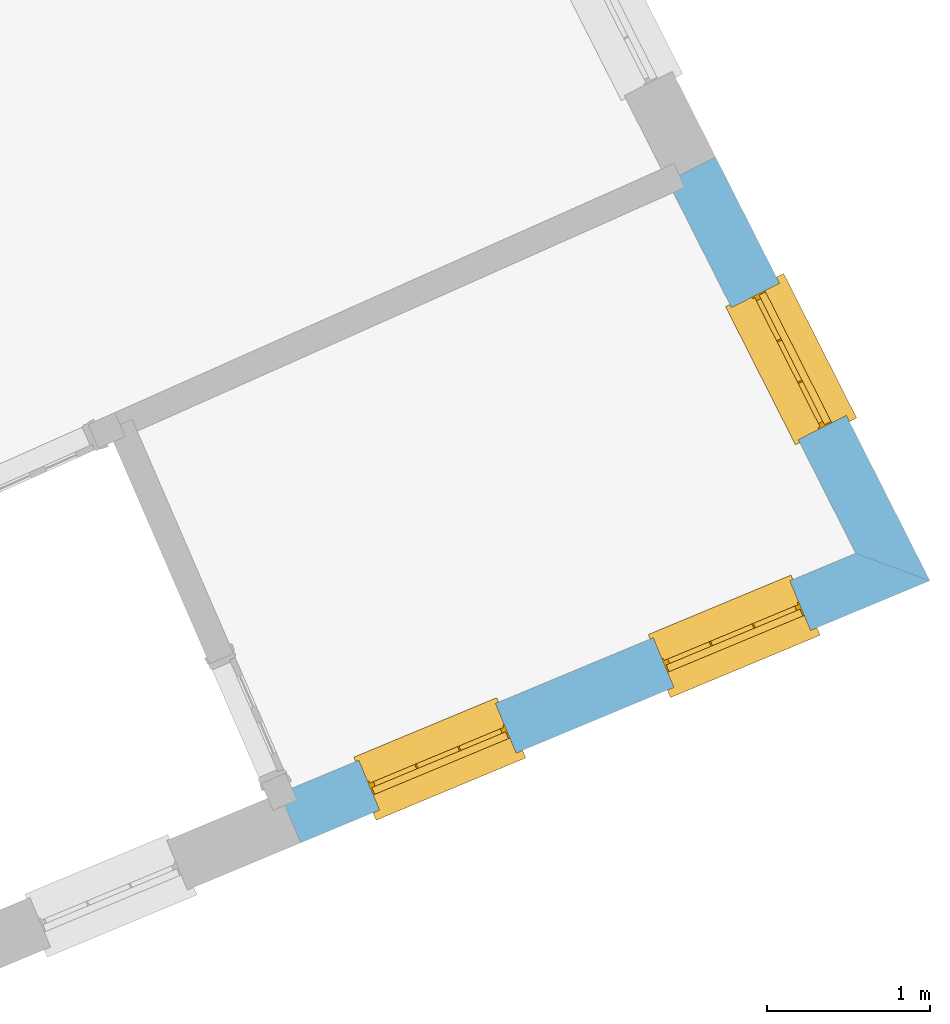
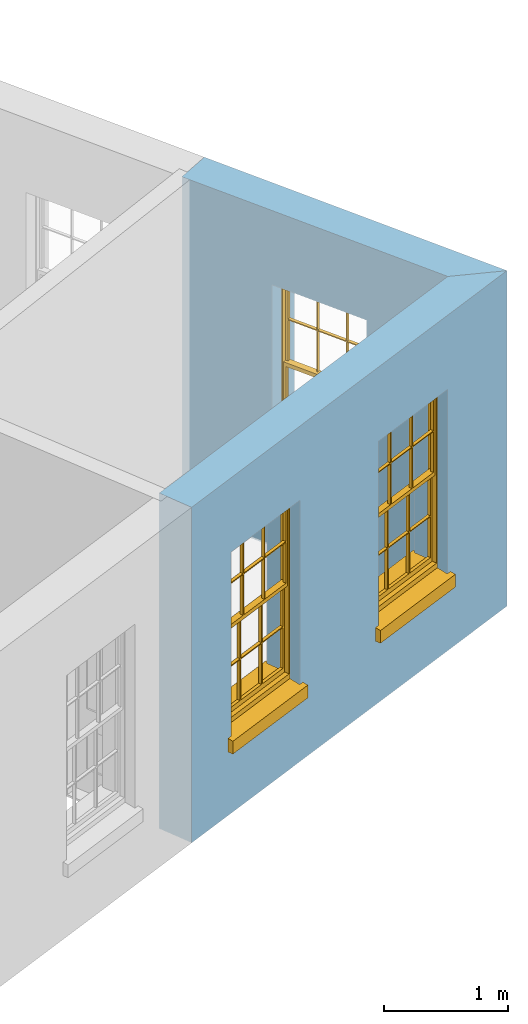
# One storey, part 6 of 8: 3 windows, 3 openings, plus 2 elements that do not belong to this part.
"""IFC2X3 building model written with IfcOpenShell, lengths in metres."""

from ifc_helpers import new_model, si_unit, frame, origin, place, context, subcontext, project, spatial, polyline, outline, extrude, faceted_brep, material, layer, layer_set, layer_usage, element, fill, save


model = new_model("IFC2X3")

# Units and contexts
model_context = context("Model", 3, world=origin())
body_context = subcontext(model_context, "Body", "Model", "MODEL_VIEW")
ifc_project = project(units=[si_unit("PLANEANGLEUNIT", "RADIAN"), si_unit("MASSUNIT", "GRAM", prefix="KILO"), si_unit("FORCEUNIT", "NEWTON", prefix="KILO"), si_unit("LENGTHUNIT", "METRE")], contexts=[model_context])

# Site, building, storey
site_placement = place(None, origin())
site = spatial("IfcSite", under=ifc_project, at=site_placement, CompositionType="ELEMENT")
building_placement = place(None, origin())
building = spatial("IfcBuilding", under=site, at=building_placement, Name="Building plot-1", CompositionType="ELEMENT")
storey_placement = place(None, frame((0.0, 0.0, 5.15)))
storey = spatial("IfcBuildingStorey", under=building, at=storey_placement, Name="Floor 1", CompositionType="ELEMENT", Elevation=5.15)

# Wall, openings, windows
ifc_material = material(Name="Masonry")
ifc_layer = layer(ifc_material, 0.33, ventilated=False)
ifc_layer_set = layer_set([ifc_layer], Name="My Wall")
ifc_layer_usage = layer_usage(ifc_layer_set, "AXIS2", "NEGATIVE", 0.08)
wall_1_placement = place(storey_placement, origin())
wall_1 = element("IfcWallStandardCase", 1, at=wall_1_placement, inside=storey, material=ifc_layer_usage, Name="exterior", context=body_context, shape_type="SweptSolid", body=[
    extrude(outline(polyline([(28.7035398456304, 43.2516426971912), (28.8304515653399, 42.947022580652), (32.693625357205, 44.5565092916169), (32.2388263663203, 44.7245240587508), (28.7035398456304, 43.2516426971912)])), origin(), (0.0, 0.0, 1.0), 3.3),
])
opening_1_placement = place(storey_placement, frame((0.0, 0.0, 0.75)))
opening_1 = element("IfcOpeningElement", 2, at=opening_1_placement, cuts=wall_1, Name="Opening", ObjectType="Opening", context=body_context, shape_type="SweptSolid", body=[
    extrude(outline(polyline([(29.314138627022, 43.1485376923154), (30.1541516756604, 43.4985063739387), (30.0272399559509, 43.8031264904779), (29.1872269073124, 43.4531578088546), (29.314138627022, 43.1485376923154)])), origin(), (0.0, 0.0, 1.0), 1.82),
])
opening_2_placement = place(storey_placement, frame((0.0, 0.0, 0.75)))
opening_2 = element("IfcOpeningElement", 3, at=opening_2_placement, cuts=wall_1, Name="Opening", ObjectType="Opening", context=body_context, shape_type="SweptSolid", body=[
    extrude(outline(polyline([(31.1215257990245, 43.9015365972656), (31.9615388476629, 44.2515052788889), (31.8346271279534, 44.5561253954281), (30.994614079315, 44.2061567138048), (31.1215257990245, 43.9015365972656)])), origin(), (0.0, 0.0, 1.0), 1.82),
])
window_1_placement = place(storey_placement, frame((29.2179933848178, 43.3793105078754, 0.75), z_axis=(0.0, 0.0, 1.0), x_axis=(0.840013048638443, 0.349968681623295, 0.0)))
window_1 = element("IfcWindow", 4, at=window_1_placement, inside=storey, Name="toilet outside window", OverallHeight=1.82, OverallWidth=0.91, context=body_context, shape_type="Brep", held_by="IfcProductRepresentation", body=[
    faceted_brep([(0.033125, -0.105, 0.975209), (0.01, -0.105, 0.975209), (0.033125, -0.105, 1.376042), (0.876875, -0.105, 0.975209), (0.876875, -0.105, 1.376042), (0.9, -0.105, 0.975209), (0.876875, -0.105, 1.386042), (0.876875, -0.105, 1.786875), (0.9, -0.105, 1.81), (0.033125, -0.105, 1.786875), (0.033125, -0.105, 1.386042), (0.01, -0.105, 1.81), (0.876875, -0.135, 1.376042), (0.876875, -0.135, 0.975209), (0.9, -0.135, 0.937083), (0.033125, -0.135, 1.786875), (0.01, -0.135, 1.81), (0.033125, -0.135, 1.386042), (0.01, -0.135, 0.937083), (0.033125, -0.135, 0.975209), (0.033125, -0.135, 1.376042), (0.876875, -0.135, 1.786875), (0.876875, -0.135, 1.386042), (0.9, -0.135, 1.81), (0.033125, -0.105, 0.937083), (0.01, -0.105, 0.937083), (0.033125, -0.105, 0.53625), (0.876875, -0.105, 0.937083), (0.876875, -0.105, 0.53625), (0.9, -0.105, 0.937083), (0.876875, -0.105, 0.52625), (0.876875, -0.105, 0.125417), (0.9, -0.105, 0.077167), (0.033125, -0.105, 0.125417), (0.033125, -0.105, 0.52625), (0.01, -0.105, 0.077167), (-0.0425, -0.25, 0.01), (-0.0425, -0.3, 0.001667), (0.0, -0.25, 0.01), (0.9525, -0.25, 0.01), (0.91, -0.25, 0.01), (0.9525, -0.3, 0.001667), (-0.02, 0.08, 0.077167), (0.0, 0.08, 0.077167), (-0.02, 0.11, 0.077167), (0.0, -0.06, 0.077167), (0.01, -0.06, 0.077167), (0.91, -0.06, 0.077167), (0.91, 0.08, 0.077167), (0.9, -0.06, 0.077167), (0.93, 0.08, 0.077167), (0.93, 0.11, 0.077167), (0.01, -0.075, 0.975209), (0.9, -0.075, 0.975209), (0.876875, -0.075, 0.125417), (0.876875, -0.075, 0.52625), (0.9, -0.075, 0.077167), (0.876875, -0.075, 0.53625), (0.876875, -0.075, 0.937083), (0.033125, -0.075, 0.125417), (0.01, -0.075, 0.077167), (0.033125, -0.075, 0.52625), (0.033125, -0.075, 0.937083), (0.033125, -0.075, 0.53625), (-0.02, 0.08, 0.052167), (-0.02, 0.11, 0.052167), (0.93, 0.11, 0.052167), (0.93, 0.08, 0.052167), (0.91, 0.08, 0.052167), (0.0, 0.08, 0.052167), (0.91, -0.15, 0.026667), (0.0, -0.15, 0.026667), (-0.0425, -0.3, -0.123333), (0.9525, -0.3, -0.123333), (-0.0425, -0.25, -0.123333), (0.9525, -0.25, -0.123333), (0.01, -0.06, 1.81), (0.9, -0.06, 1.81), (0.0, -0.06, 1.82), (0.91, -0.06, 1.82), (0.01, -0.15, 0.077167), (0.9, -0.15, 0.077167), (0.592292, -0.105, 0.125417), (0.592292, -0.075, 0.125417), (0.317708, -0.075, 0.125417), (0.317708, -0.105, 0.125417), (0.592292, -0.105, 0.53625), (0.317708, -0.105, 0.53625), (0.317708, -0.105, 0.52625), (0.592292, -0.105, 0.52625), (0.592292, -0.075, 0.53625), (0.317708, -0.075, 0.53625), (0.592292, -0.135, 1.386042), (0.592292, -0.105, 1.386042), (0.317708, -0.105, 1.386042), (0.317708, -0.135, 1.386042), (0.317708, -0.135, 1.376042), (0.592292, -0.135, 1.376042), (0.317708, -0.105, 1.376042), (0.592292, -0.105, 1.376042), (0.602292, -0.135, 1.376042), (0.592292, -0.135, 0.975209), (0.602292, -0.135, 0.975209), (0.602292, -0.105, 0.975209), (0.592292, -0.105, 0.975209), (0.602292, -0.105, 1.376042), (0.602292, -0.075, 0.53625), (0.602292, -0.105, 0.53625), (0.317708, -0.075, 0.52625), (0.307708, -0.075, 0.125417), (0.307708, -0.075, 0.52625), (0.602292, -0.075, 0.52625), (0.602292, -0.075, 0.125417), (0.592292, -0.075, 0.52625), (0.307708, -0.075, 0.53625), (0.317708, -0.075, 0.937083), (0.307708, -0.075, 0.937083), (0.602292, -0.075, 0.937083), (0.592292, -0.075, 0.937083), (0.307708, -0.105, 0.52625), (0.307708, -0.105, 0.125417), (0.307708, -0.105, 0.53625), (0.307708, -0.105, 0.937083), (0.592292, -0.105, 0.937083), (0.317708, -0.105, 0.937083), (0.602292, -0.105, 0.937083), (0.602292, -0.105, 0.52625), (0.602292, -0.105, 0.125417), (0.307708, -0.135, 1.386042), (0.307708, -0.135, 1.376042), (0.307708, -0.135, 0.975209), (0.317708, -0.135, 0.975209), (0.317708, -0.135, 1.786875), (0.307708, -0.135, 1.786875), (0.602292, -0.135, 1.786875), (0.592292, -0.135, 1.786875), (0.602292, -0.135, 1.386042), (0.602292, -0.105, 1.386042), (0.307708, -0.105, 1.386042), (0.307708, -0.105, 1.786875), (0.317708, -0.105, 1.786875), (0.592292, -0.105, 1.786875), (0.602292, -0.105, 1.786875), (0.307708, -0.105, 1.376042), (0.317708, -0.105, 0.975209), (0.307708, -0.105, 0.975209), (0.91, -0.15, 1.82), (0.9, -0.15, 1.81), (0.01, -0.15, 1.81), (0.0, -0.15, 1.82), (0.91, -0.25, 0.0), (0.0, -0.25, 0.0), (0.91, 0.08, 0.0), (0.0, 0.08, 0.0)], [[[0, 1, 2]], [[3, 4, 5]], [[6, 7, 8]], [[9, 10, 11]], [[12, 13, 14]], [[15, 16, 17]], [[18, 19, 20]], [[21, 22, 23]], [[24, 25, 26]], [[27, 28, 29]], [[30, 31, 32]], [[33, 34, 35]], [[14, 27, 29]], [[25, 24, 18]], [[36, 37, 38]], [[39, 40, 41]], [[42, 43, 44]], [[45, 46, 43]], [[47, 48, 49]], [[50, 51, 48]], [[1, 0, 52]], [[5, 53, 3]], [[54, 55, 56]], [[57, 58, 53]], [[59, 60, 61]], [[62, 63, 52]], [[48, 43, 46, 49]], [[51, 44, 43, 48]], [[64, 42, 44, 65]], [[65, 44, 51, 66]], [[66, 51, 50, 67]], [[65, 66, 68, 69]], [[60, 56, 49, 46]], [[70, 71, 38, 40]], [[37, 41, 40, 38]], [[37, 72, 73, 41]], [[74, 75, 73, 72]], [[8, 11, 76, 77]], [[76, 78, 79, 77]], [[32, 35, 80, 81]], [[81, 80, 71, 70]], [[82, 83, 84, 85]], [[86, 87, 88, 89]], [[86, 90, 91, 87]], [[92, 93, 94, 95]], [[92, 95, 96, 97]], [[96, 98, 99, 97]], [[100, 97, 101, 102]], [[103, 104, 99, 105]], [[97, 99, 104, 101]], [[102, 103, 105, 100]], [[28, 57, 106, 107]], [[108, 84, 109, 110]], [[111, 112, 83, 113]], [[114, 110, 61, 63]], [[90, 113, 108, 91]], [[115, 91, 114, 116]], [[117, 106, 90, 118]], [[111, 106, 57, 55]], [[119, 110, 109, 120]], [[34, 61, 110, 119]], [[89, 113, 83, 82]], [[88, 108, 113, 89]], [[85, 84, 108, 88]], [[121, 114, 63, 26]], [[122, 116, 114, 121]], [[123, 118, 90, 86]], [[87, 91, 115, 124]], [[107, 106, 117, 125]], [[126, 111, 55, 30]], [[127, 112, 111, 126]], [[126, 30, 28, 107]], [[88, 119, 120, 85]], [[126, 89, 82, 127]], [[125, 123, 86, 107]], [[121, 26, 34, 119]], [[124, 122, 121, 87]], [[128, 17, 20, 129]], [[96, 129, 130, 131]], [[132, 133, 128, 95]], [[134, 135, 92, 136]], [[100, 12, 22, 136]], [[137, 6, 4, 105]], [[94, 138, 139, 140]], [[137, 93, 141, 142]], [[99, 98, 94, 93]], [[143, 2, 10, 138]], [[144, 145, 143, 98]], [[129, 143, 145, 130]], [[20, 2, 143, 129]], [[131, 144, 98, 96]], [[128, 138, 10, 17]], [[133, 139, 138, 128]], [[135, 141, 93, 92]], [[95, 94, 140, 132]], [[22, 6, 137, 136]], [[136, 137, 142, 134]], [[100, 105, 4, 12]], [[107, 86, 89, 126]], [[106, 111, 113, 90]], [[91, 108, 110, 114]], [[87, 121, 119, 88]], [[97, 100, 136, 92]], [[129, 96, 95, 128]], [[98, 143, 138, 94]], [[105, 99, 93, 137]], [[131, 101, 104, 144]], [[124, 115, 118, 123]], [[132, 140, 141, 135]], [[120, 109, 59, 33]], [[15, 9, 139, 133]], [[134, 142, 7, 21]], [[31, 54, 112, 127]], [[36, 74, 72, 37]], [[39, 41, 73, 75]], [[18, 14, 101, 131]], [[23, 16, 132, 135]], [[83, 56, 60, 84]], [[52, 53, 118, 115]], [[53, 52, 144, 104]], [[11, 8, 141, 140]], [[14, 18, 124, 123]], [[2, 1, 11, 10]], [[8, 5, 4, 6]], [[57, 53, 56, 55]], [[60, 52, 63, 61]], [[26, 25, 35, 34]], [[32, 29, 28, 30]], [[14, 23, 22, 12]], [[18, 20, 17, 16]], [[19, 0, 2, 20]], [[17, 10, 9, 15]], [[12, 4, 3, 13]], [[21, 7, 6, 22]], [[27, 58, 57, 28]], [[30, 55, 54, 31]], [[33, 59, 61, 34]], [[26, 63, 62, 24]], [[5, 8, 77, 53]], [[76, 11, 1, 52]], [[46, 45, 78, 76]], [[49, 77, 79, 47]], [[70, 146, 147, 81]], [[71, 80, 148, 149]], [[19, 130, 145, 0]], [[102, 13, 3, 103]], [[116, 122, 24, 62]], [[29, 32, 81, 14]], [[80, 35, 25, 18]], [[60, 46, 76, 52]], [[77, 49, 56, 53]], [[23, 14, 81, 147]], [[16, 148, 80, 18]], [[35, 85, 120]], [[120, 33, 35]], [[127, 82, 32]], [[32, 31, 127]], [[32, 82, 85, 35]], [[102, 101, 14]], [[14, 13, 102]], [[18, 131, 130]], [[130, 19, 18]], [[134, 21, 23]], [[23, 135, 134]], [[16, 15, 133]], [[133, 132, 16]], [[11, 140, 139]], [[139, 9, 11]], [[142, 141, 8]], [[8, 7, 142]], [[23, 147, 148, 16]], [[146, 149, 148, 147]], [[52, 115, 116]], [[116, 62, 52]], [[118, 53, 117]], [[58, 117, 53]], [[27, 125, 117, 58]], [[56, 83, 112]], [[112, 54, 56]], [[109, 84, 60]], [[60, 59, 109]], [[125, 27, 14]], [[14, 123, 125]], [[122, 124, 18]], [[18, 24, 122]], [[145, 144, 52]], [[52, 0, 145]], [[103, 3, 53]], [[53, 104, 103]], [[79, 78, 149, 146]], [[78, 45, 71, 149]], [[146, 70, 47, 79]], [[150, 75, 74, 151]], [[68, 66, 67]], [[48, 68, 67, 50]], [[69, 64, 65]], [[42, 64, 69, 43]], [[69, 68, 152, 153]], [[70, 68, 48, 47]], [[150, 152, 68, 70]], [[43, 69, 71, 45]], [[69, 153, 151, 71]], [[152, 150, 151, 153]], [[38, 151, 74, 36]], [[71, 151, 38]], [[39, 75, 150, 40]], [[40, 150, 70]]]),
])
fill(opening_1, window_1)
window_2_placement = place(storey_placement, frame((31.0253805568203, 44.1323094128256, 0.75), z_axis=(0.0, 0.0, 1.0), x_axis=(0.840013048638443, 0.349968681623295, 0.0)))
window_2 = element("IfcWindow", 5, at=window_2_placement, inside=storey, Name="toilet outside window", OverallHeight=1.82, OverallWidth=0.91, context=body_context, shape_type="Brep", held_by="IfcProductRepresentation", body=[
    faceted_brep([(0.033125, -0.105, 0.975209), (0.01, -0.105, 0.975209), (0.033125, -0.105, 1.376042), (0.876875, -0.105, 0.975209), (0.876875, -0.105, 1.376042), (0.9, -0.105, 0.975209), (0.876875, -0.105, 1.386042), (0.876875, -0.105, 1.786875), (0.9, -0.105, 1.81), (0.033125, -0.105, 1.786875), (0.033125, -0.105, 1.386042), (0.01, -0.105, 1.81), (0.876875, -0.135, 1.376042), (0.876875, -0.135, 0.975209), (0.9, -0.135, 0.937083), (0.033125, -0.135, 1.786875), (0.01, -0.135, 1.81), (0.033125, -0.135, 1.386042), (0.01, -0.135, 0.937083), (0.033125, -0.135, 0.975209), (0.033125, -0.135, 1.376042), (0.876875, -0.135, 1.786875), (0.876875, -0.135, 1.386042), (0.9, -0.135, 1.81), (0.033125, -0.105, 0.937083), (0.01, -0.105, 0.937083), (0.033125, -0.105, 0.53625), (0.876875, -0.105, 0.937083), (0.876875, -0.105, 0.53625), (0.9, -0.105, 0.937083), (0.876875, -0.105, 0.52625), (0.876875, -0.105, 0.125417), (0.9, -0.105, 0.077167), (0.033125, -0.105, 0.125417), (0.033125, -0.105, 0.52625), (0.01, -0.105, 0.077167), (-0.0425, -0.25, 0.01), (-0.0425, -0.3, 0.001667), (0.0, -0.25, 0.01), (0.9525, -0.25, 0.01), (0.91, -0.25, 0.01), (0.9525, -0.3, 0.001667), (-0.02, 0.08, 0.077167), (0.0, 0.08, 0.077167), (-0.02, 0.11, 0.077167), (0.0, -0.06, 0.077167), (0.01, -0.06, 0.077167), (0.91, -0.06, 0.077167), (0.91, 0.08, 0.077167), (0.9, -0.06, 0.077167), (0.93, 0.08, 0.077167), (0.93, 0.11, 0.077167), (0.01, -0.075, 0.975209), (0.9, -0.075, 0.975209), (0.876875, -0.075, 0.125417), (0.876875, -0.075, 0.52625), (0.9, -0.075, 0.077167), (0.876875, -0.075, 0.53625), (0.876875, -0.075, 0.937083), (0.033125, -0.075, 0.125417), (0.01, -0.075, 0.077167), (0.033125, -0.075, 0.52625), (0.033125, -0.075, 0.937083), (0.033125, -0.075, 0.53625), (-0.02, 0.08, 0.052167), (-0.02, 0.11, 0.052167), (0.93, 0.11, 0.052167), (0.93, 0.08, 0.052167), (0.91, 0.08, 0.052167), (0.0, 0.08, 0.052167), (0.91, -0.15, 0.026667), (0.0, -0.15, 0.026667), (-0.0425, -0.3, -0.123333), (0.9525, -0.3, -0.123333), (-0.0425, -0.25, -0.123333), (0.9525, -0.25, -0.123333), (0.01, -0.06, 1.81), (0.9, -0.06, 1.81), (0.0, -0.06, 1.82), (0.91, -0.06, 1.82), (0.01, -0.15, 0.077167), (0.9, -0.15, 0.077167), (0.592292, -0.105, 0.125417), (0.592292, -0.075, 0.125417), (0.317708, -0.075, 0.125417), (0.317708, -0.105, 0.125417), (0.592292, -0.105, 0.53625), (0.317708, -0.105, 0.53625), (0.317708, -0.105, 0.52625), (0.592292, -0.105, 0.52625), (0.592292, -0.075, 0.53625), (0.317708, -0.075, 0.53625), (0.592292, -0.135, 1.386042), (0.592292, -0.105, 1.386042), (0.317708, -0.105, 1.386042), (0.317708, -0.135, 1.386042), (0.317708, -0.135, 1.376042), (0.592292, -0.135, 1.376042), (0.317708, -0.105, 1.376042), (0.592292, -0.105, 1.376042), (0.602292, -0.135, 1.376042), (0.592292, -0.135, 0.975209), (0.602292, -0.135, 0.975209), (0.602292, -0.105, 0.975209), (0.592292, -0.105, 0.975209), (0.602292, -0.105, 1.376042), (0.602292, -0.075, 0.53625), (0.602292, -0.105, 0.53625), (0.317708, -0.075, 0.52625), (0.307708, -0.075, 0.125417), (0.307708, -0.075, 0.52625), (0.602292, -0.075, 0.52625), (0.602292, -0.075, 0.125417), (0.592292, -0.075, 0.52625), (0.307708, -0.075, 0.53625), (0.317708, -0.075, 0.937083), (0.307708, -0.075, 0.937083), (0.602292, -0.075, 0.937083), (0.592292, -0.075, 0.937083), (0.307708, -0.105, 0.52625), (0.307708, -0.105, 0.125417), (0.307708, -0.105, 0.53625), (0.307708, -0.105, 0.937083), (0.592292, -0.105, 0.937083), (0.317708, -0.105, 0.937083), (0.602292, -0.105, 0.937083), (0.602292, -0.105, 0.52625), (0.602292, -0.105, 0.125417), (0.307708, -0.135, 1.386042), (0.307708, -0.135, 1.376042), (0.307708, -0.135, 0.975209), (0.317708, -0.135, 0.975209), (0.317708, -0.135, 1.786875), (0.307708, -0.135, 1.786875), (0.602292, -0.135, 1.786875), (0.592292, -0.135, 1.786875), (0.602292, -0.135, 1.386042), (0.602292, -0.105, 1.386042), (0.307708, -0.105, 1.386042), (0.307708, -0.105, 1.786875), (0.317708, -0.105, 1.786875), (0.592292, -0.105, 1.786875), (0.602292, -0.105, 1.786875), (0.307708, -0.105, 1.376042), (0.317708, -0.105, 0.975209), (0.307708, -0.105, 0.975209), (0.91, -0.15, 1.82), (0.9, -0.15, 1.81), (0.01, -0.15, 1.81), (0.0, -0.15, 1.82), (0.91, -0.25, 0.0), (0.0, -0.25, 0.0), (0.91, 0.08, 0.0), (0.0, 0.08, 0.0)], [[[0, 1, 2]], [[3, 4, 5]], [[6, 7, 8]], [[9, 10, 11]], [[12, 13, 14]], [[15, 16, 17]], [[18, 19, 20]], [[21, 22, 23]], [[24, 25, 26]], [[27, 28, 29]], [[30, 31, 32]], [[33, 34, 35]], [[14, 27, 29]], [[25, 24, 18]], [[36, 37, 38]], [[39, 40, 41]], [[42, 43, 44]], [[45, 46, 43]], [[47, 48, 49]], [[50, 51, 48]], [[1, 0, 52]], [[5, 53, 3]], [[54, 55, 56]], [[57, 58, 53]], [[59, 60, 61]], [[62, 63, 52]], [[48, 43, 46, 49]], [[51, 44, 43, 48]], [[64, 42, 44, 65]], [[65, 44, 51, 66]], [[66, 51, 50, 67]], [[65, 66, 68, 69]], [[60, 56, 49, 46]], [[70, 71, 38, 40]], [[37, 41, 40, 38]], [[37, 72, 73, 41]], [[74, 75, 73, 72]], [[8, 11, 76, 77]], [[76, 78, 79, 77]], [[32, 35, 80, 81]], [[81, 80, 71, 70]], [[82, 83, 84, 85]], [[86, 87, 88, 89]], [[86, 90, 91, 87]], [[92, 93, 94, 95]], [[92, 95, 96, 97]], [[96, 98, 99, 97]], [[100, 97, 101, 102]], [[103, 104, 99, 105]], [[97, 99, 104, 101]], [[102, 103, 105, 100]], [[28, 57, 106, 107]], [[108, 84, 109, 110]], [[111, 112, 83, 113]], [[114, 110, 61, 63]], [[90, 113, 108, 91]], [[115, 91, 114, 116]], [[117, 106, 90, 118]], [[111, 106, 57, 55]], [[119, 110, 109, 120]], [[34, 61, 110, 119]], [[89, 113, 83, 82]], [[88, 108, 113, 89]], [[85, 84, 108, 88]], [[121, 114, 63, 26]], [[122, 116, 114, 121]], [[123, 118, 90, 86]], [[87, 91, 115, 124]], [[107, 106, 117, 125]], [[126, 111, 55, 30]], [[127, 112, 111, 126]], [[126, 30, 28, 107]], [[88, 119, 120, 85]], [[126, 89, 82, 127]], [[125, 123, 86, 107]], [[121, 26, 34, 119]], [[124, 122, 121, 87]], [[128, 17, 20, 129]], [[96, 129, 130, 131]], [[132, 133, 128, 95]], [[134, 135, 92, 136]], [[100, 12, 22, 136]], [[137, 6, 4, 105]], [[94, 138, 139, 140]], [[137, 93, 141, 142]], [[99, 98, 94, 93]], [[143, 2, 10, 138]], [[144, 145, 143, 98]], [[129, 143, 145, 130]], [[20, 2, 143, 129]], [[131, 144, 98, 96]], [[128, 138, 10, 17]], [[133, 139, 138, 128]], [[135, 141, 93, 92]], [[95, 94, 140, 132]], [[22, 6, 137, 136]], [[136, 137, 142, 134]], [[100, 105, 4, 12]], [[107, 86, 89, 126]], [[106, 111, 113, 90]], [[91, 108, 110, 114]], [[87, 121, 119, 88]], [[97, 100, 136, 92]], [[129, 96, 95, 128]], [[98, 143, 138, 94]], [[105, 99, 93, 137]], [[131, 101, 104, 144]], [[124, 115, 118, 123]], [[132, 140, 141, 135]], [[120, 109, 59, 33]], [[15, 9, 139, 133]], [[134, 142, 7, 21]], [[31, 54, 112, 127]], [[36, 74, 72, 37]], [[39, 41, 73, 75]], [[18, 14, 101, 131]], [[23, 16, 132, 135]], [[83, 56, 60, 84]], [[52, 53, 118, 115]], [[53, 52, 144, 104]], [[11, 8, 141, 140]], [[14, 18, 124, 123]], [[2, 1, 11, 10]], [[8, 5, 4, 6]], [[57, 53, 56, 55]], [[60, 52, 63, 61]], [[26, 25, 35, 34]], [[32, 29, 28, 30]], [[14, 23, 22, 12]], [[18, 20, 17, 16]], [[19, 0, 2, 20]], [[17, 10, 9, 15]], [[12, 4, 3, 13]], [[21, 7, 6, 22]], [[27, 58, 57, 28]], [[30, 55, 54, 31]], [[33, 59, 61, 34]], [[26, 63, 62, 24]], [[5, 8, 77, 53]], [[76, 11, 1, 52]], [[46, 45, 78, 76]], [[49, 77, 79, 47]], [[70, 146, 147, 81]], [[71, 80, 148, 149]], [[19, 130, 145, 0]], [[102, 13, 3, 103]], [[116, 122, 24, 62]], [[29, 32, 81, 14]], [[80, 35, 25, 18]], [[60, 46, 76, 52]], [[77, 49, 56, 53]], [[23, 14, 81, 147]], [[16, 148, 80, 18]], [[35, 85, 120]], [[120, 33, 35]], [[127, 82, 32]], [[32, 31, 127]], [[32, 82, 85, 35]], [[102, 101, 14]], [[14, 13, 102]], [[18, 131, 130]], [[130, 19, 18]], [[134, 21, 23]], [[23, 135, 134]], [[16, 15, 133]], [[133, 132, 16]], [[11, 140, 139]], [[139, 9, 11]], [[142, 141, 8]], [[8, 7, 142]], [[23, 147, 148, 16]], [[146, 149, 148, 147]], [[52, 115, 116]], [[116, 62, 52]], [[118, 53, 117]], [[58, 117, 53]], [[27, 125, 117, 58]], [[56, 83, 112]], [[112, 54, 56]], [[109, 84, 60]], [[60, 59, 109]], [[125, 27, 14]], [[14, 123, 125]], [[122, 124, 18]], [[18, 24, 122]], [[145, 144, 52]], [[52, 0, 145]], [[103, 3, 53]], [[53, 104, 103]], [[79, 78, 149, 146]], [[78, 45, 71, 149]], [[146, 70, 47, 79]], [[150, 75, 74, 151]], [[68, 66, 67]], [[48, 68, 67, 50]], [[69, 64, 65]], [[42, 64, 69, 43]], [[69, 68, 152, 153]], [[70, 68, 48, 47]], [[150, 152, 68, 70]], [[43, 69, 71, 45]], [[69, 153, 151, 71]], [[152, 150, 151, 153]], [[38, 151, 74, 36]], [[71, 151, 38]], [[39, 75, 150, 40]], [[40, 150, 70]]]),
])
fill(opening_2, window_2)

# Wall, opening, window
wall_2_placement = place(storey_placement, origin())
wall_2 = element("IfcWallStandardCase", 6, at=wall_2_placement, inside=storey, material=ifc_layer_usage, Name="exterior", context=body_context, shape_type="SweptSolid", body=[
    extrude(outline(polyline([(32.2388263663203, 44.7245240587508), (32.693625357205, 44.5565092916169), (31.3782721430408, 47.1569525196551), (31.083799749939, 47.0080028311663), (32.2388263663203, 44.7245240587508)])), origin(), (0.0, 0.0, 1.0), 3.3),
])
opening_3_placement = place(storey_placement, frame((0.0, 0.0, 0.75)))
opening_3 = element("IfcOpeningElement", 7, at=opening_3_placement, cuts=wall_2, Name="Opening", ObjectType="Opening", context=body_context, shape_type="SweptSolid", body=[
    extrude(outline(polyline([(32.180589003273, 45.5707782331861), (31.7698489531979, 46.3828081656789), (31.4753765600961, 46.2338584771901), (31.8861166101712, 45.4218285446973), (32.180589003273, 45.5707782331861)])), origin(), (0.0, 0.0, 1.0), 1.82),
])
window_3_placement = place(storey_placement, frame((31.9575038569838, 45.4579375600885, 0.75), z_axis=(0.0, 0.0, 1.0), x_axis=(-0.41074005007513, 0.812029932492806, 0.0)))
window_3 = element("IfcWindow", 8, at=window_3_placement, inside=storey, Name="toilet outside window", OverallHeight=1.82, OverallWidth=0.91, context=body_context, shape_type="Brep", held_by="IfcProductRepresentation", body=[
    faceted_brep([(0.033125, -0.105, 0.975209), (0.01, -0.105, 0.975209), (0.033125, -0.105, 1.376042), (0.876875, -0.105, 0.975209), (0.876875, -0.105, 1.376042), (0.9, -0.105, 0.975209), (0.876875, -0.105, 1.386042), (0.876875, -0.105, 1.786875), (0.9, -0.105, 1.81), (0.033125, -0.105, 1.786875), (0.033125, -0.105, 1.386042), (0.01, -0.105, 1.81), (0.876875, -0.135, 1.376042), (0.876875, -0.135, 0.975209), (0.9, -0.135, 0.937083), (0.033125, -0.135, 1.786875), (0.01, -0.135, 1.81), (0.033125, -0.135, 1.386042), (0.01, -0.135, 0.937083), (0.033125, -0.135, 0.975209), (0.033125, -0.135, 1.376042), (0.876875, -0.135, 1.786875), (0.876875, -0.135, 1.386042), (0.9, -0.135, 1.81), (0.033125, -0.105, 0.937083), (0.01, -0.105, 0.937083), (0.033125, -0.105, 0.53625), (0.876875, -0.105, 0.937083), (0.876875, -0.105, 0.53625), (0.9, -0.105, 0.937083), (0.876875, -0.105, 0.52625), (0.876875, -0.105, 0.125417), (0.9, -0.105, 0.077167), (0.033125, -0.105, 0.125417), (0.033125, -0.105, 0.52625), (0.01, -0.105, 0.077167), (-0.0425, -0.25, 0.01), (-0.0425, -0.3, 0.001667), (0.0, -0.25, 0.01), (0.9525, -0.25, 0.01), (0.91, -0.25, 0.01), (0.9525, -0.3, 0.001667), (-0.02, 0.08, 0.077167), (0.0, 0.08, 0.077167), (-0.02, 0.11, 0.077167), (0.0, -0.06, 0.077167), (0.01, -0.06, 0.077167), (0.91, -0.06, 0.077167), (0.91, 0.08, 0.077167), (0.9, -0.06, 0.077167), (0.93, 0.08, 0.077167), (0.93, 0.11, 0.077167), (0.01, -0.075, 0.975209), (0.9, -0.075, 0.975209), (0.876875, -0.075, 0.125417), (0.876875, -0.075, 0.52625), (0.9, -0.075, 0.077167), (0.876875, -0.075, 0.53625), (0.876875, -0.075, 0.937083), (0.033125, -0.075, 0.125417), (0.01, -0.075, 0.077167), (0.033125, -0.075, 0.52625), (0.033125, -0.075, 0.937083), (0.033125, -0.075, 0.53625), (-0.02, 0.08, 0.052167), (-0.02, 0.11, 0.052167), (0.93, 0.11, 0.052167), (0.93, 0.08, 0.052167), (0.91, 0.08, 0.052167), (0.0, 0.08, 0.052167), (0.91, -0.15, 0.026667), (0.0, -0.15, 0.026667), (-0.0425, -0.3, -0.123333), (0.9525, -0.3, -0.123333), (-0.0425, -0.25, -0.123333), (0.9525, -0.25, -0.123333), (0.01, -0.06, 1.81), (0.9, -0.06, 1.81), (0.0, -0.06, 1.82), (0.91, -0.06, 1.82), (0.01, -0.15, 0.077167), (0.9, -0.15, 0.077167), (0.592292, -0.105, 0.125417), (0.592292, -0.075, 0.125417), (0.317708, -0.075, 0.125417), (0.317708, -0.105, 0.125417), (0.592292, -0.105, 0.53625), (0.317708, -0.105, 0.53625), (0.317708, -0.105, 0.52625), (0.592292, -0.105, 0.52625), (0.592292, -0.075, 0.53625), (0.317708, -0.075, 0.53625), (0.592292, -0.135, 1.386042), (0.592292, -0.105, 1.386042), (0.317708, -0.105, 1.386042), (0.317708, -0.135, 1.386042), (0.317708, -0.135, 1.376042), (0.592292, -0.135, 1.376042), (0.317708, -0.105, 1.376042), (0.592292, -0.105, 1.376042), (0.602292, -0.135, 1.376042), (0.592292, -0.135, 0.975209), (0.602292, -0.135, 0.975209), (0.602292, -0.105, 0.975209), (0.592292, -0.105, 0.975209), (0.602292, -0.105, 1.376042), (0.602292, -0.075, 0.53625), (0.602292, -0.105, 0.53625), (0.317708, -0.075, 0.52625), (0.307708, -0.075, 0.125417), (0.307708, -0.075, 0.52625), (0.602292, -0.075, 0.52625), (0.602292, -0.075, 0.125417), (0.592292, -0.075, 0.52625), (0.307708, -0.075, 0.53625), (0.317708, -0.075, 0.937083), (0.307708, -0.075, 0.937083), (0.602292, -0.075, 0.937083), (0.592292, -0.075, 0.937083), (0.307708, -0.105, 0.52625), (0.307708, -0.105, 0.125417), (0.307708, -0.105, 0.53625), (0.307708, -0.105, 0.937083), (0.592292, -0.105, 0.937083), (0.317708, -0.105, 0.937083), (0.602292, -0.105, 0.937083), (0.602292, -0.105, 0.52625), (0.602292, -0.105, 0.125417), (0.307708, -0.135, 1.386042), (0.307708, -0.135, 1.376042), (0.307708, -0.135, 0.975209), (0.317708, -0.135, 0.975209), (0.317708, -0.135, 1.786875), (0.307708, -0.135, 1.786875), (0.602292, -0.135, 1.786875), (0.592292, -0.135, 1.786875), (0.602292, -0.135, 1.386042), (0.602292, -0.105, 1.386042), (0.307708, -0.105, 1.386042), (0.307708, -0.105, 1.786875), (0.317708, -0.105, 1.786875), (0.592292, -0.105, 1.786875), (0.602292, -0.105, 1.786875), (0.307708, -0.105, 1.376042), (0.317708, -0.105, 0.975209), (0.307708, -0.105, 0.975209), (0.91, -0.15, 1.82), (0.9, -0.15, 1.81), (0.01, -0.15, 1.81), (0.0, -0.15, 1.82), (0.91, -0.25, 0.0), (0.0, -0.25, 0.0), (0.91, 0.08, 0.0), (0.0, 0.08, 0.0)], [[[0, 1, 2]], [[3, 4, 5]], [[6, 7, 8]], [[9, 10, 11]], [[12, 13, 14]], [[15, 16, 17]], [[18, 19, 20]], [[21, 22, 23]], [[24, 25, 26]], [[27, 28, 29]], [[30, 31, 32]], [[33, 34, 35]], [[14, 27, 29]], [[25, 24, 18]], [[36, 37, 38]], [[39, 40, 41]], [[42, 43, 44]], [[45, 46, 43]], [[47, 48, 49]], [[50, 51, 48]], [[1, 0, 52]], [[5, 53, 3]], [[54, 55, 56]], [[57, 58, 53]], [[59, 60, 61]], [[62, 63, 52]], [[48, 43, 46, 49]], [[51, 44, 43, 48]], [[64, 42, 44, 65]], [[65, 44, 51, 66]], [[66, 51, 50, 67]], [[65, 66, 68, 69]], [[60, 56, 49, 46]], [[70, 71, 38, 40]], [[37, 41, 40, 38]], [[37, 72, 73, 41]], [[74, 75, 73, 72]], [[8, 11, 76, 77]], [[76, 78, 79, 77]], [[32, 35, 80, 81]], [[81, 80, 71, 70]], [[82, 83, 84, 85]], [[86, 87, 88, 89]], [[86, 90, 91, 87]], [[92, 93, 94, 95]], [[92, 95, 96, 97]], [[96, 98, 99, 97]], [[100, 97, 101, 102]], [[103, 104, 99, 105]], [[97, 99, 104, 101]], [[102, 103, 105, 100]], [[28, 57, 106, 107]], [[108, 84, 109, 110]], [[111, 112, 83, 113]], [[114, 110, 61, 63]], [[90, 113, 108, 91]], [[115, 91, 114, 116]], [[117, 106, 90, 118]], [[111, 106, 57, 55]], [[119, 110, 109, 120]], [[34, 61, 110, 119]], [[89, 113, 83, 82]], [[88, 108, 113, 89]], [[85, 84, 108, 88]], [[121, 114, 63, 26]], [[122, 116, 114, 121]], [[123, 118, 90, 86]], [[87, 91, 115, 124]], [[107, 106, 117, 125]], [[126, 111, 55, 30]], [[127, 112, 111, 126]], [[126, 30, 28, 107]], [[88, 119, 120, 85]], [[126, 89, 82, 127]], [[125, 123, 86, 107]], [[121, 26, 34, 119]], [[124, 122, 121, 87]], [[128, 17, 20, 129]], [[96, 129, 130, 131]], [[132, 133, 128, 95]], [[134, 135, 92, 136]], [[100, 12, 22, 136]], [[137, 6, 4, 105]], [[94, 138, 139, 140]], [[137, 93, 141, 142]], [[99, 98, 94, 93]], [[143, 2, 10, 138]], [[144, 145, 143, 98]], [[129, 143, 145, 130]], [[20, 2, 143, 129]], [[131, 144, 98, 96]], [[128, 138, 10, 17]], [[133, 139, 138, 128]], [[135, 141, 93, 92]], [[95, 94, 140, 132]], [[22, 6, 137, 136]], [[136, 137, 142, 134]], [[100, 105, 4, 12]], [[107, 86, 89, 126]], [[106, 111, 113, 90]], [[91, 108, 110, 114]], [[87, 121, 119, 88]], [[97, 100, 136, 92]], [[129, 96, 95, 128]], [[98, 143, 138, 94]], [[105, 99, 93, 137]], [[131, 101, 104, 144]], [[124, 115, 118, 123]], [[132, 140, 141, 135]], [[120, 109, 59, 33]], [[15, 9, 139, 133]], [[134, 142, 7, 21]], [[31, 54, 112, 127]], [[36, 74, 72, 37]], [[39, 41, 73, 75]], [[18, 14, 101, 131]], [[23, 16, 132, 135]], [[83, 56, 60, 84]], [[52, 53, 118, 115]], [[53, 52, 144, 104]], [[11, 8, 141, 140]], [[14, 18, 124, 123]], [[2, 1, 11, 10]], [[8, 5, 4, 6]], [[57, 53, 56, 55]], [[60, 52, 63, 61]], [[26, 25, 35, 34]], [[32, 29, 28, 30]], [[14, 23, 22, 12]], [[18, 20, 17, 16]], [[19, 0, 2, 20]], [[17, 10, 9, 15]], [[12, 4, 3, 13]], [[21, 7, 6, 22]], [[27, 58, 57, 28]], [[30, 55, 54, 31]], [[33, 59, 61, 34]], [[26, 63, 62, 24]], [[5, 8, 77, 53]], [[76, 11, 1, 52]], [[46, 45, 78, 76]], [[49, 77, 79, 47]], [[70, 146, 147, 81]], [[71, 80, 148, 149]], [[19, 130, 145, 0]], [[102, 13, 3, 103]], [[116, 122, 24, 62]], [[29, 32, 81, 14]], [[80, 35, 25, 18]], [[60, 46, 76, 52]], [[77, 49, 56, 53]], [[23, 14, 81, 147]], [[16, 148, 80, 18]], [[35, 85, 120]], [[120, 33, 35]], [[127, 82, 32]], [[32, 31, 127]], [[32, 82, 85, 35]], [[102, 101, 14]], [[14, 13, 102]], [[18, 131, 130]], [[130, 19, 18]], [[134, 21, 23]], [[23, 135, 134]], [[16, 15, 133]], [[133, 132, 16]], [[11, 140, 139]], [[139, 9, 11]], [[142, 141, 8]], [[8, 7, 142]], [[23, 147, 148, 16]], [[146, 149, 148, 147]], [[52, 115, 116]], [[116, 62, 52]], [[118, 53, 117]], [[58, 117, 53]], [[27, 125, 117, 58]], [[56, 83, 112]], [[112, 54, 56]], [[109, 84, 60]], [[60, 59, 109]], [[125, 27, 14]], [[14, 123, 125]], [[122, 124, 18]], [[18, 24, 122]], [[145, 144, 52]], [[52, 0, 145]], [[103, 3, 53]], [[53, 104, 103]], [[79, 78, 149, 146]], [[78, 45, 71, 149]], [[146, 70, 47, 79]], [[150, 75, 74, 151]], [[68, 66, 67]], [[48, 68, 67, 50]], [[69, 64, 65]], [[42, 64, 69, 43]], [[69, 68, 152, 153]], [[70, 68, 48, 47]], [[150, 152, 68, 70]], [[43, 69, 71, 45]], [[69, 153, 151, 71]], [[152, 150, 151, 153]], [[38, 151, 74, 36]], [[71, 151, 38]], [[39, 75, 150, 40]], [[40, 150, 70]]]),
])
fill(opening_3, window_3)

save(model, "model.ifc")
